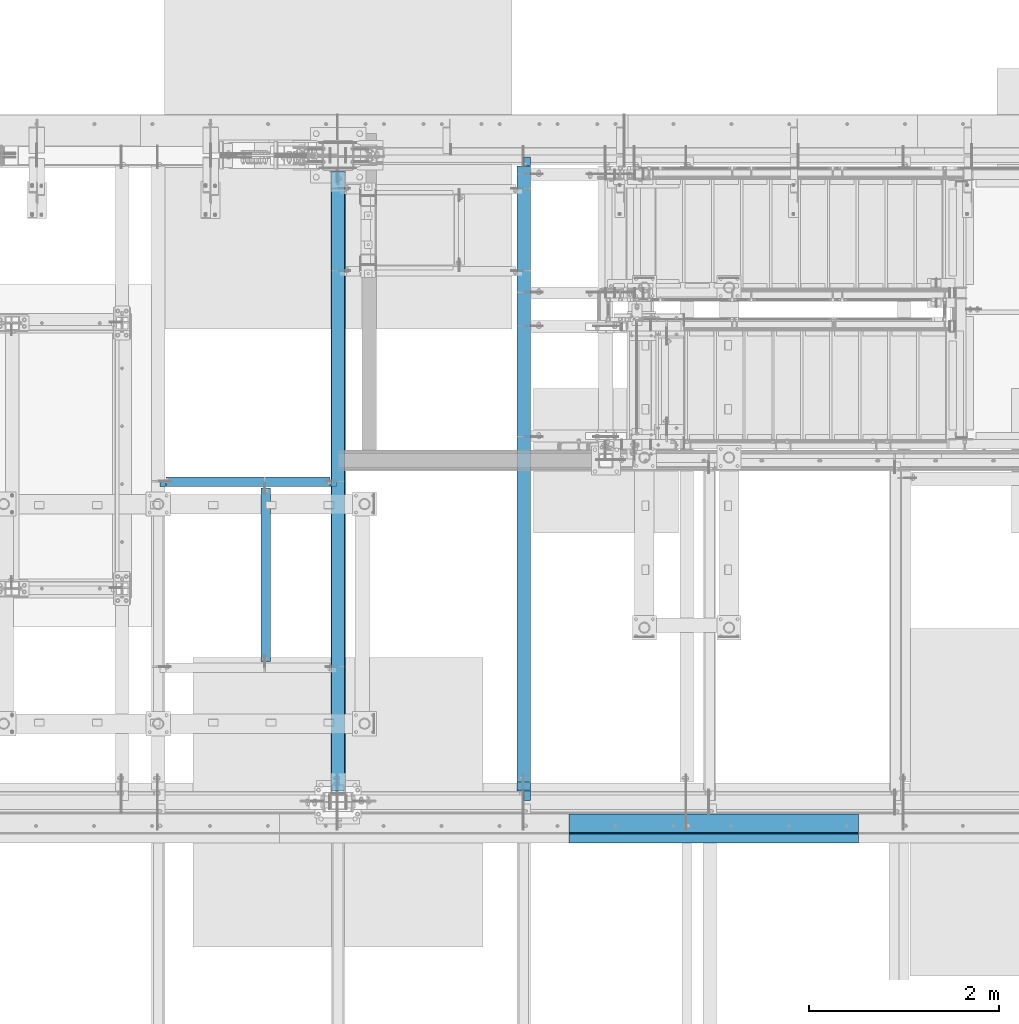
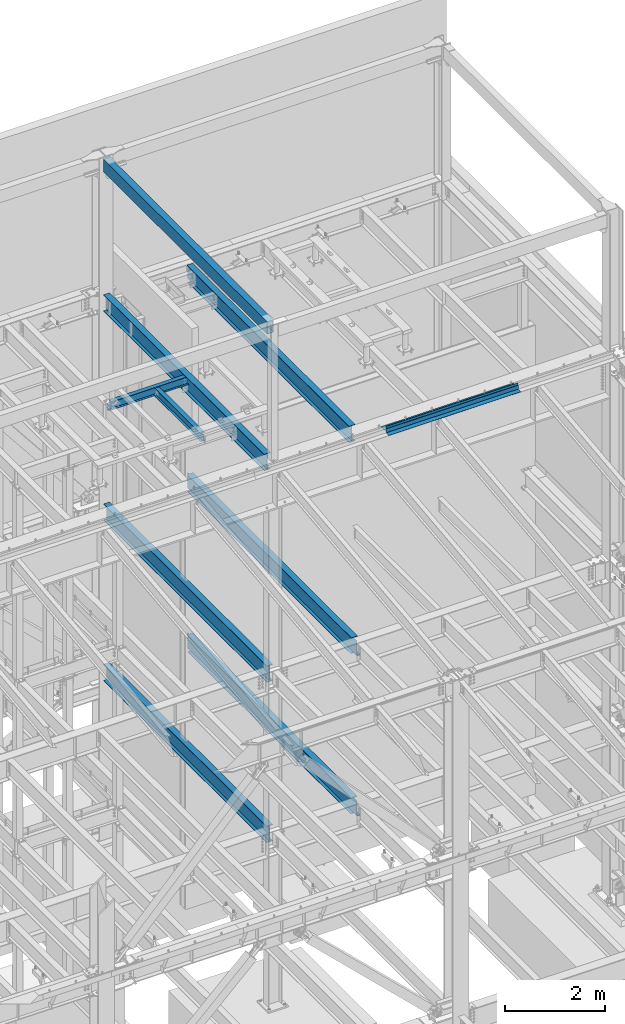
# One storey, part 774 of 1179: 11 beams, 11 elements without a shape of their own.
"""IFC2X3 building model written with IfcOpenShell, lengths in millimetres."""

from ifc_helpers import new_model, si_unit, frame, origin_with_axes, place, context, subcontext, project, spatial, faceted_brep, material, type_object, element, aggregate, save


model = new_model("IFC2X3")

# Units and contexts
model_context = context("Model", 3, precision=1e-05, world=origin_with_axes())
body_context = subcontext(model_context, "Body", "Model", "MODEL_VIEW")
ifc_project = project(units=[si_unit("LENGTHUNIT", "METRE", prefix="MILLI"), si_unit("AREAUNIT", "SQUARE_METRE"), si_unit("VOLUMEUNIT", "CUBIC_METRE"), si_unit("MASSUNIT", "GRAM", prefix="KILO"), si_unit("TIMEUNIT", "SECOND"), si_unit("PLANEANGLEUNIT", "RADIAN"), si_unit("SOLIDANGLEUNIT", "STERADIAN"), si_unit("THERMODYNAMICTEMPERATUREUNIT", "DEGREE_CELSIUS"), si_unit("LUMINOUSINTENSITYUNIT", "LUMEN")], contexts=[model_context])

# Site, building, storey
site_placement = place(None, origin_with_axes())
site = spatial("IfcSite", under=ifc_project, at=site_placement, CompositionType="ELEMENT")
building_placement = place(site_placement, origin_with_axes())
building = spatial("IfcBuilding", under=site, at=building_placement, Name="Undefined", CompositionType="ELEMENT")
storey_placement = place(building_placement, origin_with_axes())
storey = spatial("IfcBuildingStorey", under=building, at=storey_placement, Name="Undefined", CompositionType="ELEMENT", Elevation=0.0)

# Assembly, beam
assembly_1_placement = place(storey_placement, origin_with_axes())
assembly_1 = element("IfcElementAssembly", 1, at=assembly_1_placement, inside=storey, Name="BEAM", AssemblyPlace="NOTDEFINED", PredefinedType="RIGID_FRAME")
ifc_material_1 = material(Name="STEEL/A992")
beam_type_1 = type_object("IfcBeamType", Name="W16X31", PredefinedType="NOTDEFINED")
beam_1_placement = place(assembly_1_placement, frame((18415.0, 34391.6, 12917.4875), z_axis=(0.0, 0.0, 1.0), x_axis=(0.0, 1.0, 0.0)))
beam_1 = element("IfcBeam", 2, at=beam_1_placement, type_object=beam_type_1, material=ifc_material_1, Name="BEAM", ObjectType="W16X31", context=body_context, shape_type="Brep", body=[
    faceted_brep([(212.724999999999, 69.8499999999985, -190.5), (212.724999999999, 3.17499999999927, -190.5), (6661.94375000001, 3.17499999999927, -190.5), (6661.94375000001, 69.8499999999985, -190.5), (212.724999999999, -3.17499999999927, -190.5), (212.724999999999, -69.8499999999985, -190.5), (6788.94375000001, -69.8499999999985, -190.5), (6788.94375000001, -3.17499999999927, -190.5), (212.724999999999, -69.8499999999985, -201.612499999999), (6788.94375000001, -69.8499999999985, -201.612499999999), (6788.94375000001, 3.17549991607666, -201.612499999999), (6788.94375000001, 3.17499999999927, -190.5), (6788.94375000001, 3.17499999999927, 163.512499999999), (6788.94375000001, -3.17499999999927, 163.512499999999), (6661.94375000001, 3.17549991607666, -201.612499999999), (212.724999999999, 69.8499999999985, -201.612499999999), (6661.94375000001, 69.8499999999985, -201.612499999999), (212.724999999999, -3.17499999999927, 190.5), (212.724999999999, -69.8499999999985, 190.5), (212.724999999999, -69.8499999999985, 201.612499999999), (212.724999999999, 69.8499999999985, 201.612499999999), (212.724999999999, 69.8499999999985, 190.5), (212.724999999999, 3.17499999999927, 190.5), (212.724999999999, 3.17499999999927, 162.664998864024), (212.724999999999, 3.17499999999927, -142.027500567505), (6696.86875000001, 69.8499999999985, 190.5), (6696.86875000001, 3.17499999999927, 190.5), (6696.86875000001, 3.17499999999927, 176.212499809264), (6697.8354799226, 3.17499999999927, 171.352420291218), (6700.58849382307, 3.17499999999927, 167.232243823064), (6704.70867029123, 3.17499999999927, 164.479229922586), (6709.56874980927, 3.17499999999927, 163.512499999999), (6697.8354799226, -3.17499999999927, 171.352420291218), (6696.86875000001, -3.17499999999927, 176.212499809264), (6700.58849382307, -3.17499999999927, 167.232243823064), (6704.70867029123, -3.17499999999927, 164.479229922586), (6709.56874980927, -3.17499999999927, 163.512499999999), (6696.86875000001, -3.17499999999927, 190.5), (6696.86875000001, -69.8499999999985, 190.5), (6696.86875000001, -69.8499999999985, 201.612499999999), (6696.86875000001, 69.8499999999985, 201.612499999999)], [[[0, 1, 2, 3]], [[4, 5, 6, 7]], [[5, 8, 9, 6]], [[7, 6, 9, 10, 11, 12, 13]], [[11, 10, 14, 2]], [[9, 8, 15, 16, 14, 10]], [[2, 14, 16, 3]], [[15, 0, 3, 16]], [[8, 5, 4, 17, 18, 19, 20, 21, 22, 23, 24, 1, 0, 15]], [[22, 21, 25, 26]], [[11, 2, 1, 24, 23, 22, 26, 27, 28, 29, 30, 31, 12]], [[32, 28, 27, 33]], [[34, 29, 28, 32]], [[35, 30, 29, 34]], [[36, 31, 30, 35]], [[13, 12, 31, 36]], [[35, 34, 32, 33, 37, 17, 4, 7, 13, 36]], [[18, 17, 37, 38]], [[19, 18, 38, 39]], [[20, 19, 39, 40]], [[21, 20, 40, 25]], [[39, 38, 37, 33, 27, 26, 25, 40]]]),
])
aggregate(assembly_1, [beam_1])

assembly_2_placement = place(storey_placement, origin_with_axes())
assembly_2 = element("IfcElementAssembly", 3, at=assembly_2_placement, inside=storey, Name="BEAM", AssemblyPlace="NOTDEFINED", PredefinedType="RIGID_FRAME")
beam_2_placement = place(assembly_2_placement, frame((16459.2, 34391.6, 12917.4875), z_axis=(0.0, 0.0, 1.0), x_axis=(0.0, 1.0, 0.0)))
beam_2 = element("IfcBeam", 4, at=beam_2_placement, type_object=beam_type_1, material=ifc_material_1, Name="BEAM", ObjectType="W16X31", context=body_context, shape_type="Brep", body=[
    faceted_brep([(212.724999999999, -69.8499999999985, -201.612499999999), (212.724999999999, 69.8499999999985, -201.612499999999), (6637.33750000001, 69.8499999999985, -201.612499999999), (6637.33750000001, -69.8499999999985, -201.612499999999), (212.724999999999, -69.8499999999985, -190.5), (212.724999999999, -3.17499999999927, -190.5), (212.724999999999, -3.17499999999927, 190.5), (212.724999999999, -69.8499999999985, 190.5), (212.724999999999, -69.8499999999985, 201.612499999999), (212.724999999999, 69.8499999999985, 201.612499999999), (212.724999999999, 69.8499999999985, 190.5), (212.724999999999, 3.17499999999927, 190.5), (212.724999999999, 3.17499999999927, 162.664998864024), (212.724999999999, 3.17499999999927, -142.027500567505), (212.724999999999, 3.17499999999927, -190.5), (212.724999999999, 69.8499999999985, -190.5), (6637.33750000001, -69.8499999999985, -190.5), (6637.33750000001, -3.17499999999927, -190.5), (6637.33750000001, -3.17499999999927, 190.5), (6637.33750000001, -69.8499999999985, 190.5), (6637.33750000001, -69.8499999999985, 201.612499999999), (6637.33750000001, 69.8499999999985, 201.612499999999), (6637.33750000001, 69.8499999999985, 190.5), (6637.33750000001, 3.17499999999927, 190.5), (6637.33750000001, 3.17499999999927, -190.5), (6637.33750000001, 69.8499999999985, -190.5)], [[[0, 1, 2, 3]], [[0, 4, 5, 6, 7, 8, 9, 10, 11, 12, 13, 14, 15, 1]], [[5, 4, 16, 17]], [[6, 5, 17, 18]], [[7, 6, 18, 19]], [[8, 7, 19, 20]], [[9, 8, 20, 21]], [[10, 9, 21, 22]], [[11, 10, 22, 23]], [[14, 13, 12, 11, 23, 24]], [[15, 14, 24, 25]], [[1, 15, 25, 2]], [[24, 23, 22, 21, 20, 19, 18, 17, 16, 3, 2, 25]], [[4, 0, 3, 16]]]),
])
aggregate(assembly_2, [beam_2])

assembly_3_placement = place(storey_placement, origin_with_axes())
assembly_3 = element("IfcElementAssembly", 5, at=assembly_3_placement, inside=storey, Name="BEAM", AssemblyPlace="NOTDEFINED", PredefinedType="RIGID_FRAME")
beam_3_placement = place(assembly_3_placement, frame((18415.0, 34391.6, 7812.0875), z_axis=(0.0, 0.0, 1.0), x_axis=(0.0, 1.0, 0.0)))
beam_3 = element("IfcBeam", 6, at=beam_3_placement, type_object=beam_type_1, material=ifc_material_1, Name="BEAM", ObjectType="W16X31", context=body_context, shape_type="Brep", body=[
    faceted_brep([(104.775000190733, -3.17499999999927, 166.6875), (104.775000190733, 3.17497120592088, 166.6875), (17.4624999999942, 3.17499999999927, 166.6875), (17.4624999999942, -3.17499999999927, 166.6875), (109.63507970878, -3.17499999999927, 167.654229922588), (109.63507970878, 3.17497058299341, 167.654229922588), (113.755256176933, -3.17499999999927, 170.407243823066), (113.755256176933, 3.17496880904946, 170.407243823066), (116.508270077407, -3.17499999999927, 174.52742029122), (116.508270077407, 3.17496615415439, 174.52742029122), (117.474999999999, -3.17499999999927, 179.387499809265), (117.474999999999, 3.17496302249128, 179.387499809265), (117.474999999999, -69.8499999999985, 201.6125), (117.474999999999, 69.8499999999985, 201.6125), (117.474999999999, 69.8499999999985, 190.5), (117.474999999999, 3.17499999999927, 190.5), (117.474999999999, -3.17499999999927, 190.5), (117.474999999999, -69.8499999999985, 190.5), (6661.94375000001, 3.17499999999927, -190.5), (6661.94375000001, 69.8499999999985, -190.5), (144.462499999994, 69.8499999999985, -190.5), (144.462499999994, 3.17549991607666, -190.5), (17.4624999999942, -3.17499999999927, -190.5), (17.4624999999942, -69.8499999999985, -190.5), (6788.94375000001, -69.8499999999985, -190.5), (6788.94375000001, -3.17499999999927, -190.5), (17.4624999999942, -69.8499999999985, -201.6125), (6788.94375000001, -69.8499999999985, -201.612499999999), (6661.94375000001, 69.8499999999985, -201.612499999999), (6661.94375000001, 3.17549991607666, -201.612499999999), (6788.94375000001, 3.17549991607666, -201.612499999999), (17.4624999999942, 3.17549991607666, -201.6125), (144.462499999994, 3.17549991607666, -201.6125), (144.462499999994, 69.8499999999985, -201.6125), (17.4624999999942, 3.17499999999927, -190.5), (6788.94375000001, 3.17499999999927, -190.5), (6788.94375000001, 3.17499999999927, 163.512499999999), (6788.94375000001, -3.17499999999927, 163.512499999999), (6709.56874980927, 3.17499999999927, 163.512499999999), (6709.56874980927, -3.17499999999927, 163.512499999999), (6704.70867029123, 3.17499999999927, 164.479229922586), (6704.70867029123, -3.17499999999927, 164.479229922586), (6700.58849382307, 3.17499999999927, 167.232243823064), (6700.58849382307, -3.17499999999927, 167.232243823064), (6697.8354799226, 3.17499999999927, 171.352420291218), (6697.8354799226, -3.17499999999927, 171.352420291218), (6696.86875000001, 3.17499999999927, 176.212499809264), (6696.86875000001, -3.17499999999927, 176.212499809264), (6696.86875000001, -69.8499999999985, 201.612499999999), (6696.86875000001, -69.8499999999985, 190.5), (6696.86875000001, -3.17499999999927, 190.5), (6696.86875000001, 3.17499999999927, 190.5), (6696.86875000001, 69.8499999999985, 190.5), (6696.86875000001, 69.8499999999985, 201.612499999999)], [[[0, 1, 2, 3]], [[4, 5, 1, 0]], [[6, 7, 5, 4]], [[8, 9, 7, 6]], [[10, 11, 9, 8]], [[12, 13, 14, 15, 11, 10, 16, 17]], [[18, 19, 20, 21]], [[22, 23, 24, 25]], [[23, 26, 27, 24]], [[28, 29, 30, 27, 26, 31, 32, 33]], [[21, 32, 31, 34]], [[20, 33, 32, 21]], [[19, 28, 33, 20]], [[18, 29, 28, 19]], [[35, 30, 29, 18]], [[25, 24, 27, 30, 35, 36, 37]], [[37, 36, 38, 39]], [[39, 38, 40, 41]], [[41, 40, 42, 43]], [[43, 42, 44, 45]], [[45, 44, 46, 47]], [[48, 49, 50, 47, 46, 51, 52, 53]], [[49, 48, 12, 17]], [[50, 49, 17, 16]], [[8, 6, 4, 0, 3, 22, 25, 37, 39, 41, 43, 45, 47, 50, 16, 10]], [[34, 31, 26, 23, 22, 3, 2]], [[51, 46, 44, 42, 40, 38, 36, 35, 18, 21, 34, 2, 1, 5, 7, 9, 11, 15]], [[52, 51, 15, 14]], [[53, 52, 14, 13]], [[48, 53, 13, 12]]]),
])
aggregate(assembly_3, [beam_3])

assembly_4_placement = place(storey_placement, origin_with_axes())
assembly_4 = element("IfcElementAssembly", 7, at=assembly_4_placement, inside=storey, Name="BEAM", AssemblyPlace="NOTDEFINED", PredefinedType="RIGID_FRAME")
beam_4_placement = place(assembly_4_placement, frame((16459.2, 34391.6, 7812.0875), z_axis=(0.0, 0.0, 1.0), x_axis=(0.0, 1.0, 0.0)))
beam_4 = element("IfcBeam", 8, at=beam_4_placement, type_object=beam_type_1, material=ifc_material_1, Name="BEAM", ObjectType="W16X31", context=body_context, shape_type="Brep", body=[
    faceted_brep([(115.887499999997, -69.8499999999985, -201.6125), (115.887499999997, 69.8499999999985, -201.6125), (6637.33750000001, 69.8499999999985, -201.612499999999), (6637.33750000001, -69.8499999999985, -201.612499999999), (115.887499999997, -69.8499999999985, -190.5), (115.887499999997, -3.17499999999927, -190.5), (115.887499999997, -3.17499999999927, 190.5), (115.887499999997, -69.8499999999985, 190.5), (115.887499999997, -69.8499999999985, 201.6125), (115.887499999997, 69.8499999999985, 201.6125), (115.887499999997, 69.8499999999985, 190.5), (115.887499999997, 3.17499999999927, 190.5), (115.887499999997, 3.17499999999927, 164.252489941818), (115.887499999997, 3.17499999999927, -142.027503290603), (115.887499999997, 3.17499999999927, -190.5), (115.887499999997, 69.8499999999985, -190.5), (6637.33750000001, -69.8499999999985, -190.5), (6637.33750000001, -3.17499999999927, -190.5), (6637.33750000001, -3.17499999999927, 190.5), (6637.33750000001, -69.8499999999985, 190.5), (6637.33750000001, -69.8499999999985, 201.612499999999), (6637.33750000001, 69.8499999999985, 201.612499999999), (6637.33750000001, 69.8499999999985, 190.5), (6637.33750000001, 3.17499999999927, 190.5), (6637.33750000001, 3.17499999999927, -190.5), (6637.33750000001, 69.8499999999985, -190.5)], [[[0, 1, 2, 3]], [[0, 4, 5, 6, 7, 8, 9, 10, 11, 12, 13, 14, 15, 1]], [[5, 4, 16, 17]], [[6, 5, 17, 18]], [[7, 6, 18, 19]], [[8, 7, 19, 20]], [[9, 8, 20, 21]], [[10, 9, 21, 22]], [[11, 10, 22, 23]], [[14, 13, 12, 11, 23, 24]], [[15, 14, 24, 25]], [[1, 15, 25, 2]], [[24, 23, 22, 21, 20, 19, 18, 17, 16, 3, 2, 25]], [[4, 0, 3, 16]]]),
])
aggregate(assembly_4, [beam_4])

assembly_5_placement = place(storey_placement, origin_with_axes())
assembly_5 = element("IfcElementAssembly", 9, at=assembly_5_placement, inside=storey, Name="BEAM", AssemblyPlace="NOTDEFINED", PredefinedType="RIGID_FRAME")
beam_5_placement = place(assembly_5_placement, frame((16459.2, 34391.6, 3900.4875), z_axis=(0.0, 0.0, 1.0), x_axis=(0.0, 1.0, 0.0)))
beam_5 = element("IfcBeam", 10, at=beam_5_placement, type_object=beam_type_1, material=ifc_material_1, Name="BEAM", ObjectType="W16X31", context=body_context, shape_type="Brep", body=[
    faceted_brep([(115.887499999997, -69.8499999999985, -201.6125), (115.887499999997, 69.8499999999985, -201.6125), (6637.33750000001, 69.8499999999985, -201.612499999999), (6637.33750000001, -69.8499999999985, -201.612499999999), (115.887499999997, -69.8499999999985, -190.5), (115.887499999997, -3.17499999999927, -190.5), (115.887499999997, -3.17499999999927, 190.5), (115.887499999997, -69.8499999999985, 190.5), (115.887499999997, -69.8499999999985, 201.6125), (115.887499999997, 69.8499999999985, 201.6125), (115.887499999997, 69.8499999999985, 190.5), (115.887499999997, 3.17499999999927, 190.5), (115.887499999997, 3.17499999999927, 164.252489941818), (115.887499999997, 3.17499999999927, -142.027503290603), (115.887499999997, 3.17499999999927, -190.5), (115.887499999997, 69.8499999999985, -190.5), (6637.33750000001, -69.8499999999985, -190.5), (6637.33750000001, -3.17499999999927, -190.5), (6637.33750000001, -3.17499999999927, 190.5), (6637.33750000001, -69.8499999999985, 190.5), (6637.33750000001, -69.8499999999985, 201.612499999999), (6637.33750000001, 69.8499999999985, 201.612499999999), (6637.33750000001, 69.8499999999985, 190.5), (6637.33750000001, 3.17499999999927, 190.5), (6637.33750000001, 3.17499999999927, -190.5), (6637.33750000001, 69.8499999999985, -190.5)], [[[0, 1, 2, 3]], [[0, 4, 5, 6, 7, 8, 9, 10, 11, 12, 13, 14, 15, 1]], [[5, 4, 16, 17]], [[6, 5, 17, 18]], [[7, 6, 18, 19]], [[8, 7, 19, 20]], [[9, 8, 20, 21]], [[10, 9, 21, 22]], [[11, 10, 22, 23]], [[14, 13, 12, 11, 23, 24]], [[15, 14, 24, 25]], [[1, 15, 25, 2]], [[24, 23, 22, 21, 20, 19, 18, 17, 16, 3, 2, 25]], [[4, 0, 3, 16]]]),
])
aggregate(assembly_5, [beam_5])

assembly_6_placement = place(storey_placement, origin_with_axes())
assembly_6 = element("IfcElementAssembly", 11, at=assembly_6_placement, inside=storey, Name="BEAM", AssemblyPlace="NOTDEFINED", PredefinedType="RIGID_FRAME")
beam_6_placement = place(assembly_6_placement, frame((18415.0, 34391.6, 3900.4875), z_axis=(0.0, 0.0, 1.0), x_axis=(0.0, 1.0, 0.0)))
beam_6 = element("IfcBeam", 12, at=beam_6_placement, type_object=beam_type_1, material=ifc_material_1, Name="BEAM", ObjectType="W16X31", context=body_context, shape_type="Brep", body=[
    faceted_brep([(113.506251936145, -3.17499999997744, 169.8625), (113.506251936145, 3.17496422017757, 169.8625), (18.2562514952835, 3.17499999999927, 169.8625), (18.2562514952835, -3.17499999999927, 169.8625), (118.366331454192, -3.17499999997926, 170.829229922588), (118.366331454192, 3.17496349569046, 170.829229922588), (122.486507922345, -3.17499999997744, 173.582243823066), (122.486507922345, 3.17496143253265, 173.582243823066), (125.239521822827, -3.17499999997563, 177.70242029122), (125.239521822819, 3.17495834479632, 177.70242029122), (126.206251745411, -3.17499999997744, 182.562499809265), (126.206251745411, 3.1749547025629, 182.562499809265), (126.206251745432, -69.8499999999767, 201.6125), (126.206251745396, 69.850000000024, 201.6125), (126.206251745396, 69.850000000024, 190.5), (126.206251745418, 3.17500000002292, 190.5), (126.206251745411, -3.17499999997744, 190.5), (126.206251745432, -69.8499999999767, 190.5), (6661.94375000001, 3.17499999999927, -190.5), (6661.94375000001, 69.8499999999985, -190.5), (145.256250000001, 69.8499999999985, -190.5), (145.256250000001, 3.17549991607666, -190.5), (18.2562500000006, -3.17500000000291, -190.5), (18.2562500000006, -69.8499999999985, -190.5), (6788.94375000001, -69.8499999999985, -190.5), (6788.94375000001, -3.17499999999927, -190.5), (18.2562500000006, -69.8499999999985, -201.612499999999), (6788.94375000001, -69.8499999999985, -201.612499999999), (6661.94375000001, 69.8499999999985, -201.612499999999), (6661.94375000001, 3.17549991607666, -201.612499999999), (6788.94375000001, 3.17549991607666, -201.612499999999), (18.2562500000006, 3.17549991607666, -201.612499999999), (145.256250000001, 3.17549991607666, -201.612499999999), (145.256250000001, 69.8499999999985, -201.612499999999), (18.2562500000006, 3.17500000000291, -190.5), (6788.94375000001, 3.17499999999927, -190.5), (6788.94375000001, 3.17499999999927, 169.8625), (6788.94375000001, -3.17499999999927, 169.8625), (6709.56874980927, 3.17499999999927, 169.8625), (6709.56874980927, -3.17499999999927, 169.8625), (6704.70867029123, 3.17499999999927, 170.829229922588), (6704.70867029123, -3.17499999999927, 170.829229922588), (6700.58849382307, 3.17499999999927, 173.582243823066), (6700.58849382307, -3.17499999999927, 173.582243823066), (6697.8354799226, 3.17499999999927, 177.702420291219), (6697.8354799226, -3.17499999999927, 177.702420291219), (6696.86875000001, 3.17499999999927, 182.562499809265), (6696.86875000001, -3.17499999999927, 182.562499809265), (6696.86875000001, -69.8499999999985, 201.612499999999), (6696.86875000001, -69.8499999999985, 190.5), (6696.86875000001, -3.17499999999927, 190.5), (6696.86875000001, 3.17499999999927, 190.5), (6696.86875000001, 69.8499999999985, 190.5), (6696.86875000001, 69.8499999999985, 201.612499999999)], [[[0, 1, 2, 3]], [[4, 5, 1, 0]], [[6, 7, 5, 4]], [[8, 9, 7, 6]], [[10, 11, 9, 8]], [[12, 13, 14, 15, 11, 10, 16, 17]], [[18, 19, 20, 21]], [[22, 23, 24, 25]], [[23, 26, 27, 24]], [[28, 29, 30, 27, 26, 31, 32, 33]], [[21, 32, 31, 34]], [[20, 33, 32, 21]], [[19, 28, 33, 20]], [[18, 29, 28, 19]], [[35, 30, 29, 18]], [[25, 24, 27, 30, 35, 36, 37]], [[37, 36, 38, 39]], [[39, 38, 40, 41]], [[41, 40, 42, 43]], [[43, 42, 44, 45]], [[45, 44, 46, 47]], [[48, 49, 50, 47, 46, 51, 52, 53]], [[49, 48, 12, 17]], [[50, 49, 17, 16]], [[8, 6, 4, 0, 3, 22, 25, 37, 39, 41, 43, 45, 47, 50, 16, 10]], [[34, 31, 26, 23, 22, 3, 2]], [[51, 46, 44, 42, 40, 38, 36, 35, 18, 21, 34, 2, 1, 5, 7, 9, 11, 15]], [[52, 51, 15, 14]], [[53, 52, 14, 13]], [[48, 53, 13, 12]]]),
])
aggregate(assembly_6, [beam_6])

assembly_7_placement = place(storey_placement, origin_with_axes())
assembly_7 = element("IfcElementAssembly", 13, at=assembly_7_placement, inside=storey, Name="BENT_PLATE", AssemblyPlace="NOTDEFINED", PredefinedType="RIGID_FRAME")
ifc_material_2 = material(Name="STEEL/A36")
beam_type_2 = type_object("IfcBeamType", PredefinedType="NOTDEFINED")
beam_7_placement = place(assembly_7_placement, frame((20413.6625008647, 34061.4000000402, 13197.7319337816), z_axis=(1.0, 0.0, 0.0), x_axis=(0.0, 0.0, -1.0)))
beam_7 = element("IfcBeam", 14, at=beam_7_placement, type_object=beam_type_2, material=ifc_material_2, Name="BENT_PLATE", context=body_context, shape_type="Brep", body=[
    faceted_brep([(0.0, -3.17499999999927, -1524.0), (6.00266503170133e-10, -3.17499999922438, 1524.00000000052), (6.00266503170133e-10, 3.17500000077416, 1524.00000000052), (0.0, 3.17499999999927, -1524.0), (101.599999999993, 3.17500000000291, 1524.0), (101.599999999993, 3.17500000000291, -1524.0), (95.9271295501057, -3.17500000000291, -1524.0), (95.9271295501057, -3.17500000000291, 1524.0), (113.008063243053, -97.7824964679457, 1524.0), (113.008063243053, -97.7824964679457, -1524.0), (106.698219713815, -98.4955004206422, 1524.0), (106.698219713815, -98.4955004206422, -1524.0)], [[[0, 1, 2, 3]], [[3, 2, 4, 5]], [[1, 0, 6, 7]], [[5, 4, 8, 9]], [[4, 2, 1, 7, 10, 8]], [[7, 6, 11, 10]], [[6, 0, 3, 5, 9, 11]], [[10, 11, 9, 8]]]),
])
aggregate(assembly_7, [beam_7])

assembly_8_placement = place(storey_placement, origin_with_axes())
assembly_8 = element("IfcElementAssembly", 15, at=assembly_8_placement, inside=storey, Name="BEAM", AssemblyPlace="NOTDEFINED", PredefinedType="RIGID_FRAME")
beam_type_3 = type_object("IfcBeamType", PredefinedType="NOTDEFINED")
beam_8_placement = place(assembly_8_placement, frame((20413.6625008164, 34267.775, 13122.275), z_axis=(1.0, 0.0, 0.0), x_axis=(0.0, -1.0, 0.0)))
beam_8 = element("IfcBeam", 16, at=beam_8_placement, type_object=beam_type_3, material=ifc_material_2, Name="BENT_PLATE", context=body_context, shape_type="Brep", body=[
    faceted_brep([(0.0, -3.17499999999927, -1524.0), (6.00266503170133e-10, -3.17499999922438, 1524.00000000052), (6.00266503170133e-10, 3.17500000077416, 1524.00000000052), (0.0, 3.17499999999927, -1524.0), (203.199999999997, 3.17499999999927, 1524.0), (203.199999999997, 3.17499999999927, -1524.0), (196.849999999991, -3.17499999999927, -1524.0), (196.849999999991, -3.17499999999927, 1524.0), (203.199999999997, -130.175000000001, 1524.0), (203.199999999997, -130.175000000001, -1524.0), (196.849999999991, -130.175000000001, 1524.0), (196.849999999991, -130.175000000001, -1524.0)], [[[0, 1, 2, 3]], [[3, 2, 4, 5]], [[1, 0, 6, 7]], [[5, 4, 8, 9]], [[4, 2, 1, 7, 10, 8]], [[7, 6, 11, 10]], [[6, 0, 3, 5, 9, 11]], [[10, 11, 9, 8]]]),
])
aggregate(assembly_8, [beam_8])

assembly_9_placement = place(storey_placement, origin_with_axes())
assembly_9 = element("IfcElementAssembly", 17, at=assembly_9_placement, inside=storey, Name="BEAM", AssemblyPlace="NOTDEFINED", PredefinedType="RIGID_FRAME")
ifc_material_3 = material()
beam_type_4 = type_object("IfcBeamType", Name="HSS12X6X3/8", PredefinedType="NOTDEFINED")
beam_9_placement = place(assembly_9_placement, frame((16459.2, 34480.5, 16275.05), z_axis=(0.0, 0.0, 1.0), x_axis=(0.0, 1.0, 0.0)))
beam_9 = element("IfcBeam", 18, at=beam_9_placement, type_object=beam_type_4, material=ifc_material_3, Name="BEAM", ObjectType="HSS12X6X3/8", context=body_context, shape_type="Brep", body=[
    faceted_brep([(4.76249999999709, 66.6749999999993, -142.875), (4.76249999999709, -66.6749999999993, -142.875), (6543.67500000002, -66.6749999999993, -142.875), (6543.67500000002, 66.6749999999993, -142.875), (4.76249999999709, -66.6749999999993, 142.875000000002), (6543.67500000002, -66.6749999999993, 142.875000000002), (4.76249999999709, 66.6749999999993, 142.875000000002), (6543.67500000002, 66.6749999999993, 142.875000000002), (4.76249999999709, 76.2000000000007, -152.4), (4.76249999999709, 76.2000000000007, 152.4), (6543.67500000002, 76.2000000000007, 152.4), (6543.67500000002, 76.2000000000007, -152.4), (4.76249999999709, -76.2000000000007, 152.4), (6543.67500000002, -76.2000000000007, 152.4), (4.76249999999709, -76.2000000000007, -152.4), (6543.67500000002, -76.2000000000007, -152.4)], [[[0, 1, 2, 3]], [[1, 4, 5, 2]], [[4, 6, 7, 5]], [[6, 0, 3, 7]], [[8, 9, 10, 11]], [[9, 12, 13, 10]], [[12, 14, 15, 13]], [[14, 8, 11, 15]], [[13, 15, 11, 10], [5, 7, 3, 2]], [[14, 12, 9, 8], [6, 4, 1, 0]]]),
])
aggregate(assembly_9, [beam_9])

assembly_10_placement = place(storey_placement, origin_with_axes())
assembly_10 = element("IfcElementAssembly", 19, at=assembly_10_placement, inside=storey, Name="BEAM", AssemblyPlace="NOTDEFINED", PredefinedType="RIGID_FRAME")
beam_type_5 = type_object("IfcBeamType", Name="W8X10", PredefinedType="NOTDEFINED")
beam_10_placement = place(assembly_10_placement, frame((15697.2, 35807.65, 13019.0875), z_axis=(0.0, 0.0, 1.0), x_axis=(0.0, 1.0, 0.0)))
beam_10 = element("IfcBeam", 20, at=beam_10_placement, type_object=beam_type_5, material=ifc_material_1, Name="BEAM", ObjectType="W8X10", context=body_context, shape_type="Brep", body=[
    faceted_brep([(15.0812499999956, -2.38125000000036, -77.7874999999985), (15.0812499999956, 2.38125000000036, -77.7874999999985), (51.5937501907247, 2.38125000000036, -77.7874999999985), (51.5937501907247, -2.38125000000036, -77.7874999999985), (56.4538297087711, 2.38125000000036, -78.7542299225861), (56.4538297087711, -2.38125000000036, -78.7542299225861), (60.5740061769247, 2.38125000000036, -81.5072438230636), (60.5740061769247, -2.38125000000036, -81.5072438230636), (63.3270200773986, 2.38125000000036, -85.6274202912173), (63.3270200773986, -2.38125000000036, -85.6274202912173), (64.2937499999898, -2.38125000000036, -90.4874998092637), (64.2937499999898, 2.38125000000036, -90.4874998092637), (64.2937499999898, 2.38125000000036, -95.25), (64.2937499999898, 50.7999999999993, -95.25), (64.2937499999898, 50.7999999999993, -100.012500000001), (64.2937499999898, -50.7999999999993, -100.012500000001), (64.2937499999898, -50.7999999999993, -95.25), (64.2937499999898, -2.38125000000036, -95.25), (1891.50625000001, 50.7999999999993, 95.25), (1891.50625000001, 2.38125000000036, 95.25), (64.2937499999898, 2.38125000000036, 95.25), (64.2937499999898, 50.7999999999993, 95.25), (51.5937501907247, -2.38125000000036, 77.7875000000022), (51.5937501907247, 2.38125000000036, 77.7875000000022), (15.0812499999956, 2.38125000000036, 77.7875000000022), (15.0812499999956, -2.38125000000036, 77.7875000000022), (56.4538297087711, -2.38125000000036, 78.7542299225897), (56.4538297087711, 2.38125000000036, 78.7542299225897), (60.5740061769247, -2.38125000000036, 81.5072438230673), (60.5740061769247, 2.38125000000036, 81.5072438230673), (63.3270200773986, -2.38125000000036, 85.6274202912209), (63.3270200773986, 2.38125000000036, 85.6274202912209), (64.2937499999898, -2.38125000000036, 90.4874998092673), (64.2937499999898, 2.38125000000036, 90.4874998092673), (1891.50625000001, -50.7999999999993, 100.012500000001), (1891.50625000001, 50.7999999999993, 100.012500000001), (64.2937499999898, 50.7999999999993, 100.012500000001), (64.2937499999898, -50.7999999999993, 100.012500000001), (1891.50625000001, -50.7999999999993, 95.25), (64.2937499999898, -50.7999999999993, 95.25), (1891.50625000001, -2.38125000000036, 95.25), (64.2937499999898, -2.38125000000036, 95.25), (1891.50625000001, -2.38125000000036, 90.4874998092673), (1891.50625000001, 2.38125000000036, 90.4874998092673), (1892.4729799226, -2.38125000000036, 85.6274202912209), (1892.4729799226, 2.38125000000036, 85.6274202912209), (1895.22599382307, -2.38125000000036, 81.5072438230673), (1895.22599382307, 2.38125000000036, 81.5072438230673), (1899.34617029122, -2.38125000000036, 78.7542299225897), (1899.34617029122, 2.38125000000036, 78.7542299225897), (1904.20624980927, -2.38125000000036, 77.7875000000022), (1904.20624980927, 2.38125000000036, 77.7875000000022), (1940.71875000001, -2.38125000000036, 77.7875000000022), (1940.71875000001, 2.38125000000036, 77.7875000000022), (1940.71875000001, -2.38125000000036, -77.7874999999985), (1940.71875000001, 2.38125000000036, -77.7874999999985), (1904.20624980927, -2.38125000000036, -77.7874999999985), (1904.20624980927, 2.38125000000036, -77.7874999999985), (1899.34617029122, -2.38125000000036, -78.7542299225861), (1899.34617029122, 2.38125000000036, -78.7542299225861), (1895.22599382307, -2.38125000000036, -81.5072438230636), (1895.22599382307, 2.38125000000036, -81.5072438230636), (1892.4729799226, -2.38125000000036, -85.6274202912173), (1892.4729799226, 2.38125000000036, -85.6274202912173), (1891.50625000001, -2.38125000000036, -90.4874998092637), (1891.50625000001, 2.38125000000036, -90.4874998092637), (1891.50625000001, -2.38125000000036, -95.25), (1891.50625000001, -50.7999999999993, -95.25), (1891.50625000001, -50.7999999999993, -100.012500000001), (1891.50625000001, 50.7999999999993, -100.012500000001), (1891.50625000001, 50.7999999999993, -95.25), (1891.50625000001, 2.38125000000036, -95.25)], [[[0, 1, 2, 3]], [[3, 2, 4, 5]], [[5, 4, 6, 7]], [[7, 6, 8, 9]], [[10, 11, 12, 13, 14, 15, 16, 17]], [[9, 8, 11, 10]], [[18, 19, 20, 21]], [[22, 23, 24, 25]], [[26, 27, 23, 22]], [[28, 29, 27, 26]], [[30, 31, 29, 28]], [[32, 33, 31, 30]], [[34, 35, 36, 37]], [[38, 34, 37, 39]], [[40, 38, 39, 41]], [[37, 36, 21, 20, 33, 32, 41, 39]], [[35, 18, 21, 36]], [[34, 38, 40, 42, 43, 19, 18, 35]], [[44, 45, 43, 42]], [[46, 47, 45, 44]], [[48, 49, 47, 46]], [[50, 51, 49, 48]], [[52, 53, 51, 50]], [[53, 52, 54, 55]], [[54, 56, 57, 55]], [[58, 59, 57, 56]], [[60, 61, 59, 58]], [[62, 63, 61, 60]], [[64, 65, 63, 62]], [[66, 67, 68, 69, 70, 71, 65, 64]], [[67, 66, 17, 16]], [[68, 67, 16, 15]], [[69, 68, 15, 14]], [[70, 69, 14, 13]], [[71, 70, 13, 12]], [[6, 4, 2, 1, 24, 23, 27, 29, 31, 33, 20, 19, 43, 45, 47, 49, 51, 53, 55, 57, 59, 61, 63, 65, 71, 12, 11, 8]], [[25, 24, 1, 0]], [[66, 64, 62, 60, 58, 56, 54, 52, 50, 48, 46, 44, 42, 40, 41, 32, 30, 28, 26, 22, 25, 0, 3, 5, 7, 9, 10, 17]]]),
])
aggregate(assembly_10, [beam_10])

assembly_11_placement = place(storey_placement, origin_with_axes())
assembly_11 = element("IfcElementAssembly", 21, at=assembly_11_placement, inside=storey, Name="BEAM", AssemblyPlace="NOTDEFINED", PredefinedType="RIGID_FRAME")
beam_11_placement = place(assembly_11_placement, frame((14566.9, 37763.45, 13019.0875), z_axis=(0.0, 0.0, 1.0), x_axis=(1.0, 0.0, 0.0)))
beam_11 = element("IfcBeam", 22, at=beam_11_placement, type_object=beam_type_5, material=ifc_material_1, Name="BEAM", ObjectType="W8X10", context=body_context, shape_type="Brep", body=[
    faceted_brep([(1809.75, -50.8000000000029, 100.012500000001), (1809.75, -50.8000000000029, 95.25), (1809.75, -2.38124999999854, 95.25), (1809.75, -2.38124999999854, 80.962499809264), (1809.75, 2.38121389596199, 80.962499809264), (1809.75, 2.38124999999854, 95.25), (1809.75, 50.8000000000029, 95.25), (1809.75, 50.8000000000029, 100.012500000001), (1810.71672992259, -2.38124999999854, 76.1024202912176), (1810.71672992259, 2.38122031080275, 76.1024202912176), (1813.46974382307, -2.38124999999854, 71.982243823064), (1813.46974382307, 2.38122575113084, 71.982243823064), (1817.58992029122, -2.38124999999854, 69.2292299225865), (1817.58992029122, 2.3812293887022, 69.2292299225865), (1822.44999980927, -2.38124999999854, 68.2624999999989), (1822.44999980927, 2.38123066972184, 68.2624999999989), (1876.425, -2.38124999999854, 68.2624999999989), (1876.425, 2.38124999999854, 68.2624999999989), (82.5499999999975, -50.8000000000029, 100.012500000001), (82.5499999999975, 50.8000000000029, 100.012500000001), (82.5499999999975, 50.8000000000029, 95.25), (82.5499999999975, 2.38124999999854, 95.25), (82.5499999999975, 2.3812255131852, 80.962499809264), (82.5499999999975, -2.38124999999854, 80.962499809264), (82.5499999999975, -2.38124999999854, 95.25), (82.5499999999975, -50.8000000000029, 95.25), (81.5832700774099, 2.38123189017642, 76.1024202912176), (81.5832700774099, -2.38124999999854, 76.1024202912176), (78.8302561769324, 2.38123729632207, 71.982243823064), (78.8302561769324, -2.38124999999854, 71.982243823064), (74.7100797087787, 2.38124090859492, 69.2292299225865), (74.7100797087787, -2.38124999999854, 69.2292299225865), (69.8500001907323, 2.38124217705627, 68.2624999999989), (69.8500001907323, -2.38124999999854, 68.2624999999989), (15.875, 2.38124999999854, 68.2624999999989), (15.875, -2.38124999999854, 68.2624999999989), (15.875, 2.38124999999854, -95.25), (15.875, 2.38174991607957, -100.012500000001), (15.875, -50.8000000000029, -100.012500000001), (15.875, -50.8000000000029, -95.25), (15.875, -2.38124999999854, -95.25), (142.875, 2.38174991607957, -95.25), (142.875, 2.38174991607957, -100.012500000001), (142.875, 50.8000000000029, -95.25), (142.875, 50.8000000000029, -100.012500000001), (1749.42499999983, 2.38128662388772, -95.25), (1749.425, 50.8000000000029, -95.25), (1749.425, 50.8000000000029, -100.012500000001), (1749.425, 2.38186831471103, -100.012500000001), (1876.425, 2.38124999999854, -95.25), (1876.425, 2.38186831471103, -100.012500000001), (1876.425, -50.8000000000029, -100.012500000001), (1876.425, -50.8000000000029, -95.25), (1876.425, -2.38124999999854, -95.25)], [[[0, 1, 2, 3, 4, 5, 6, 7]], [[8, 9, 4, 3]], [[10, 11, 9, 8]], [[12, 13, 11, 10]], [[14, 15, 13, 12]], [[16, 17, 15, 14]], [[18, 19, 20, 21, 22, 23, 24, 25]], [[23, 22, 26, 27]], [[27, 26, 28, 29]], [[29, 28, 30, 31]], [[31, 30, 32, 33]], [[33, 32, 34, 35]], [[36, 37, 38, 39, 40, 35, 34]], [[41, 42, 37, 36]], [[43, 44, 42, 41]], [[43, 41, 45, 46]], [[44, 43, 46, 47]], [[45, 48, 47, 46]], [[49, 50, 48, 45]], [[51, 38, 37, 42, 44, 47, 48, 50]], [[39, 38, 51, 52]], [[40, 39, 52, 53]], [[12, 10, 8, 3, 2, 24, 23, 27, 29, 31, 33, 35, 40, 53, 16, 14]], [[25, 24, 2, 1]], [[18, 25, 1, 0]], [[19, 18, 0, 7]], [[20, 19, 7, 6]], [[21, 20, 6, 5]], [[49, 45, 41, 36, 34, 32, 30, 28, 26, 22, 21, 5, 4, 9, 11, 13, 15, 17]], [[53, 52, 51, 50, 49, 17, 16]]]),
])
aggregate(assembly_11, [beam_11])

save(model, "model.ifc")
